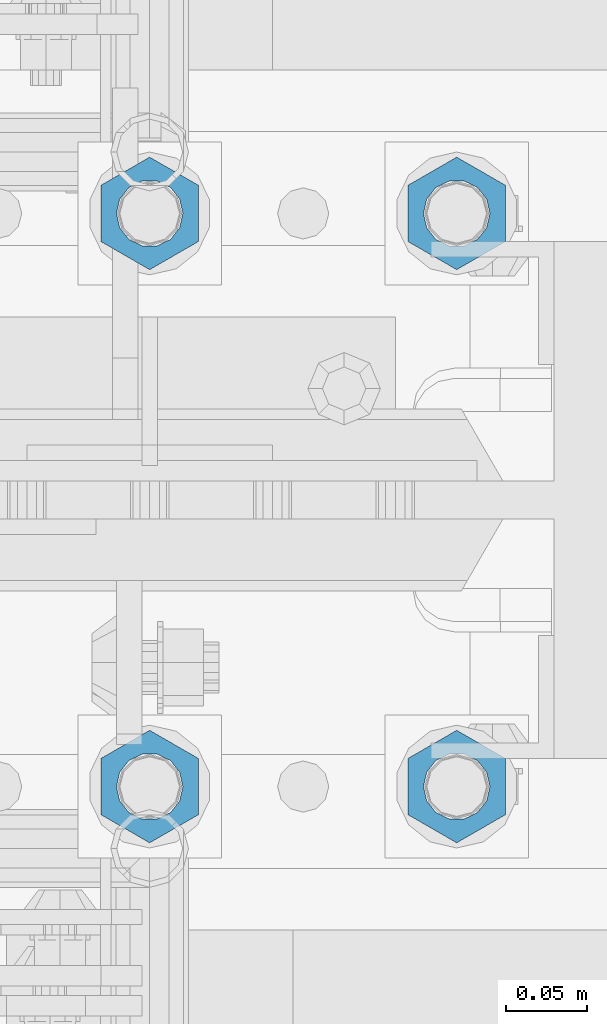
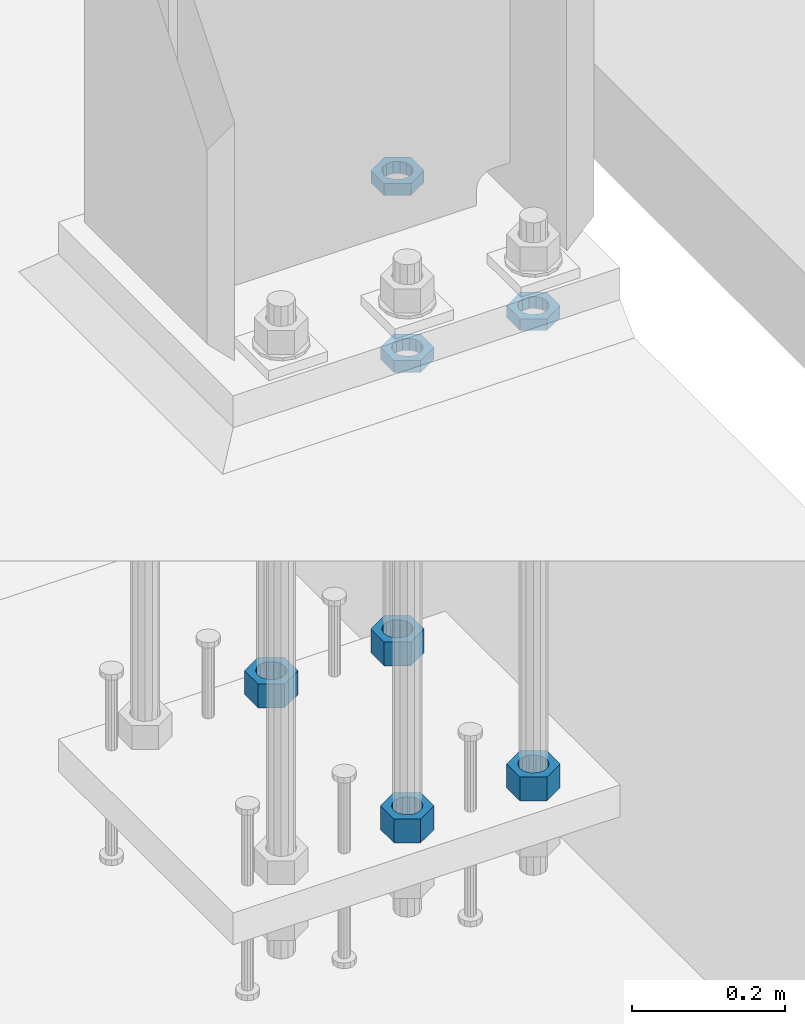
# One storey, part 1394 of 1876: 7 beams, 1 element without a shape of its own.
"""IFC2X3 building model written with IfcOpenShell, lengths in millimetres."""

from ifc_helpers import new_model, si_unit, frame, origin_with_axes, place, context, subcontext, project, spatial, faceted_brep, material, type_object, element, aggregate, save


model = new_model("IFC2X3")

# Units and contexts
model_context = context("Model", 3, precision=1e-05, world=origin_with_axes())
body_context = subcontext(model_context, "Body", "Model", "MODEL_VIEW")
ifc_project = project(units=[si_unit("LENGTHUNIT", "METRE", prefix="MILLI"), si_unit("AREAUNIT", "SQUARE_METRE"), si_unit("VOLUMEUNIT", "CUBIC_METRE"), si_unit("MASSUNIT", "GRAM", prefix="KILO"), si_unit("TIMEUNIT", "SECOND"), si_unit("PLANEANGLEUNIT", "RADIAN"), si_unit("SOLIDANGLEUNIT", "STERADIAN"), si_unit("THERMODYNAMICTEMPERATUREUNIT", "DEGREE_CELSIUS"), si_unit("LUMINOUSINTENSITYUNIT", "LUMEN")], contexts=[model_context])

# Site, building, storey
site_placement = place(None, origin_with_axes())
site = spatial("IfcSite", under=ifc_project, at=site_placement, CompositionType="ELEMENT")
building_placement = place(site_placement, origin_with_axes())
building = spatial("IfcBuilding", under=site, at=building_placement, Name="Undefined", CompositionType="ELEMENT")
storey_placement = place(building_placement, origin_with_axes())
storey = spatial("IfcBuildingStorey", under=building, at=storey_placement, Name="Undefined", CompositionType="ELEMENT", Elevation=0.0)

# Assembly, beams
assembly_placement = place(storey_placement, origin_with_axes())
assembly = element("IfcElementAssembly", 1, at=assembly_placement, inside=storey, Name="TEMPLATE", AssemblyPlace="NOTDEFINED", PredefinedType="RIGID_FRAME")
ifc_material = material(Name="STEEL/A563")
beam_type_1 = type_object("IfcBeamType", Name="1-1/2_DIA. HALF_NUT", PredefinedType="NOTDEFINED")
beam_1_placement = place(assembly_placement, frame((7810.5, -4394.2, 33.3375), z_axis=(-1.0, 0.0, 0.0), x_axis=(0.0, 0.0, -1.0)))
beam_1 = element("IfcBeam", 2, at=beam_1_placement, type_object=beam_type_1, material=ifc_material, Name="NUT", ObjectType="1-1/2_DIA. HALF_NUT", context=body_context, shape_type="Brep", body=[
    faceted_brep([(0.0, -34.9199981689453, 0.0), (0.0, -17.4599990844727, -30.25), (19.0499999999999, -17.4599990844727, -30.25), (19.0499999999999, -34.9199981689453, 0.0), (0.0, 17.4599990844727, -30.25), (19.0499999999999, 17.4599990844727, -30.25), (0.0, 34.9199981689453, 0.0), (19.0499999999999, 34.9199981689453, 0.0), (0.0, 17.4599990844727, 30.25), (19.0499999999999, 17.4599990844727, 30.25), (0.0, -17.4599990844727, 30.25), (19.0499999999999, -17.4599990844727, 30.25), (0.0, 0.0, 20.6399993896484), (0.0, 8.95536011056538, 18.5959968835978), (19.0499999999999, 8.95536011056538, 18.5959968835978), (19.0499999999999, 0.0, 20.6399993896484), (0.0, 16.1370013209489, 12.8688291298158), (19.0499999999999, 16.1370013209489, 12.8688291298158), (0.0, 20.1225115123834, 4.59283194104228), (19.0499999999999, 20.1225115123834, 4.59283194104228), (0.0, 20.1225115123834, -4.59283194104228), (19.0499999999999, 20.1225115123834, -4.59283194104228), (0.0, 16.1370013209489, -12.8688291298167), (19.0499999999999, 16.1370013209489, -12.8688291298167), (0.0, 8.95536011056538, -18.5959968835978), (19.0499999999999, 8.95536011056538, -18.5959968835978), (0.0, 0.0, -20.6399993896484), (19.0499999999999, 0.0, -20.6399993896484), (0.0, -8.95536011056538, -18.5959968835978), (19.0499999999999, -8.95536011056538, -18.5959968835978), (0.0, -16.1370013209489, -12.8688291298158), (19.0499999999999, -16.1370013209489, -12.8688291298158), (0.0, -20.1225115123834, -4.59283194104228), (19.0499999999999, -20.1225115123834, -4.59283194104228), (0.0, -20.1225115123834, 4.59283194104228), (19.0499999999999, -20.1225115123834, 4.59283194104228), (0.0, -16.1370013209489, 12.8688291298167), (19.0499999999999, -16.1370013209489, 12.8688291298167), (0.0, -8.95536011056538, 18.5959968835978), (19.0499999999999, -8.95536011056538, 18.5959968835978)], [[[0, 1, 2, 3]], [[1, 4, 5, 2]], [[4, 6, 7, 5]], [[6, 8, 9, 7]], [[8, 10, 11, 9]], [[10, 0, 3, 11]], [[12, 13, 14, 15]], [[13, 16, 17, 14]], [[16, 18, 19, 17]], [[18, 20, 21, 19]], [[20, 22, 23, 21]], [[22, 24, 25, 23]], [[24, 26, 27, 25]], [[26, 28, 29, 27]], [[28, 30, 31, 29]], [[30, 32, 33, 31]], [[32, 34, 35, 33]], [[34, 36, 37, 35]], [[36, 38, 39, 37]], [[38, 12, 15, 39]], [[5, 7, 9, 11, 3, 2], [17, 19, 21, 23, 25, 27, 29, 31, 33, 35, 37, 39, 15, 14]], [[10, 8, 6, 4, 1, 0], [38, 36, 34, 32, 30, 28, 26, 24, 22, 20, 18, 16, 13, 12]]]),
])
beam_2_placement = place(assembly_placement, frame((7620.0, -4749.8, 33.3375), z_axis=(1.0, 0.0, 0.0), x_axis=(0.0, 0.0, -1.0)))
beam_2 = element("IfcBeam", 3, at=beam_2_placement, type_object=beam_type_1, material=ifc_material, Name="NUT", ObjectType="1-1/2_DIA. HALF_NUT", context=body_context, shape_type="Brep", body=[
    faceted_brep([(0.0, -34.9199981689453, 0.0), (0.0, -17.4599990844727, -30.25), (19.0499999999999, -17.4599990844727, -30.25), (19.0499999999999, -34.9199981689453, 0.0), (0.0, 17.4599990844727, -30.25), (19.0499999999999, 17.4599990844727, -30.25), (0.0, 34.9199981689453, 0.0), (19.0499999999999, 34.9199981689453, 0.0), (0.0, 17.4599990844727, 30.25), (19.0499999999999, 17.4599990844727, 30.25), (0.0, -17.4599990844727, 30.25), (19.0499999999999, -17.4599990844727, 30.25), (0.0, 0.0, 20.6399993896484), (0.0, 8.95536011056538, 18.5959968835978), (19.0499999999999, 8.95536011056538, 18.5959968835978), (19.0499999999999, 0.0, 20.6399993896484), (0.0, 16.1370013209489, 12.8688291298158), (19.0499999999999, 16.1370013209489, 12.8688291298158), (0.0, 20.1225115123834, 4.59283194104228), (19.0499999999999, 20.1225115123834, 4.59283194104228), (0.0, 20.1225115123834, -4.59283194104228), (19.0499999999999, 20.1225115123834, -4.59283194104228), (0.0, 16.1370013209489, -12.8688291298167), (19.0499999999999, 16.1370013209489, -12.8688291298167), (0.0, 8.95536011056538, -18.5959968835978), (19.0499999999999, 8.95536011056538, -18.5959968835978), (0.0, 0.0, -20.6399993896484), (19.0499999999999, 0.0, -20.6399993896484), (0.0, -8.95536011056538, -18.5959968835978), (19.0499999999999, -8.95536011056538, -18.5959968835978), (0.0, -16.1370013209489, -12.8688291298158), (19.0499999999999, -16.1370013209489, -12.8688291298158), (0.0, -20.1225115123834, -4.59283194104228), (19.0499999999999, -20.1225115123834, -4.59283194104228), (0.0, -20.1225115123834, 4.59283194104228), (19.0499999999999, -20.1225115123834, 4.59283194104228), (0.0, -16.1370013209489, 12.8688291298167), (19.0499999999999, -16.1370013209489, 12.8688291298167), (0.0, -8.95536011056538, 18.5959968835978), (19.0499999999999, -8.95536011056538, 18.5959968835978)], [[[0, 1, 2, 3]], [[1, 4, 5, 2]], [[4, 6, 7, 5]], [[6, 8, 9, 7]], [[8, 10, 11, 9]], [[10, 0, 3, 11]], [[12, 13, 14, 15]], [[13, 16, 17, 14]], [[16, 18, 19, 17]], [[18, 20, 21, 19]], [[20, 22, 23, 21]], [[22, 24, 25, 23]], [[24, 26, 27, 25]], [[26, 28, 29, 27]], [[28, 30, 31, 29]], [[30, 32, 33, 31]], [[32, 34, 35, 33]], [[34, 36, 37, 35]], [[36, 38, 39, 37]], [[38, 12, 15, 39]], [[5, 7, 9, 11, 3, 2], [17, 19, 21, 23, 25, 27, 29, 31, 33, 35, 37, 39, 15, 14]], [[10, 8, 6, 4, 1, 0], [38, 36, 34, 32, 30, 28, 26, 24, 22, 20, 18, 16, 13, 12]]]),
])
beam_3_placement = place(assembly_placement, frame((7810.5, -4749.8, 33.3375), z_axis=(1.0, 0.0, 0.0), x_axis=(0.0, 0.0, -1.0)))
beam_3 = element("IfcBeam", 4, at=beam_3_placement, type_object=beam_type_1, material=ifc_material, Name="NUT", ObjectType="1-1/2_DIA. HALF_NUT", context=body_context, shape_type="Brep", body=[
    faceted_brep([(0.0, -34.9199981689453, 0.0), (0.0, -17.4599990844727, -30.25), (19.0499999999999, -17.4599990844727, -30.25), (19.0499999999999, -34.9199981689453, 0.0), (0.0, 17.4599990844727, -30.25), (19.0499999999999, 17.4599990844727, -30.25), (0.0, 34.9199981689453, 0.0), (19.0499999999999, 34.9199981689453, 0.0), (0.0, 17.4599990844727, 30.25), (19.0499999999999, 17.4599990844727, 30.25), (0.0, -17.4599990844727, 30.25), (19.0499999999999, -17.4599990844727, 30.25), (0.0, 0.0, 20.6399993896484), (0.0, 8.95536011056538, 18.5959968835978), (19.0499999999999, 8.95536011056538, 18.5959968835978), (19.0499999999999, 0.0, 20.6399993896484), (0.0, 16.1370013209489, 12.8688291298158), (19.0499999999999, 16.1370013209489, 12.8688291298158), (0.0, 20.1225115123834, 4.59283194104228), (19.0499999999999, 20.1225115123834, 4.59283194104228), (0.0, 20.1225115123834, -4.59283194104228), (19.0499999999999, 20.1225115123834, -4.59283194104228), (0.0, 16.1370013209489, -12.8688291298167), (19.0499999999999, 16.1370013209489, -12.8688291298167), (0.0, 8.95536011056538, -18.5959968835978), (19.0499999999999, 8.95536011056538, -18.5959968835978), (0.0, 0.0, -20.6399993896484), (19.0499999999999, 0.0, -20.6399993896484), (0.0, -8.95536011056538, -18.5959968835978), (19.0499999999999, -8.95536011056538, -18.5959968835978), (0.0, -16.1370013209489, -12.8688291298158), (19.0499999999999, -16.1370013209489, -12.8688291298158), (0.0, -20.1225115123834, -4.59283194104228), (19.0499999999999, -20.1225115123834, -4.59283194104228), (0.0, -20.1225115123834, 4.59283194104228), (19.0499999999999, -20.1225115123834, 4.59283194104228), (0.0, -16.1370013209489, 12.8688291298167), (19.0499999999999, -16.1370013209489, 12.8688291298167), (0.0, -8.95536011056538, 18.5959968835978), (19.0499999999999, -8.95536011056538, 18.5959968835978)], [[[0, 1, 2, 3]], [[1, 4, 5, 2]], [[4, 6, 7, 5]], [[6, 8, 9, 7]], [[8, 10, 11, 9]], [[10, 0, 3, 11]], [[12, 13, 14, 15]], [[13, 16, 17, 14]], [[16, 18, 19, 17]], [[18, 20, 21, 19]], [[20, 22, 23, 21]], [[22, 24, 25, 23]], [[24, 26, 27, 25]], [[26, 28, 29, 27]], [[28, 30, 31, 29]], [[30, 32, 33, 31]], [[32, 34, 35, 33]], [[34, 36, 37, 35]], [[36, 38, 39, 37]], [[38, 12, 15, 39]], [[5, 7, 9, 11, 3, 2], [17, 19, 21, 23, 25, 27, 29, 31, 33, 35, 37, 39, 15, 14]], [[10, 8, 6, 4, 1, 0], [38, 36, 34, 32, 30, 28, 26, 24, 22, 20, 18, 16, 13, 12]]]),
])
beam_type_2 = type_object("IfcBeamType", Name="1-1/2_HEAVY_HEX_NUT", PredefinedType="NOTDEFINED")
beam_4_placement = place(assembly_placement, frame((7810.5, -4749.8, -698.5), z_axis=(1.0, 0.0, 0.0), x_axis=(0.0, 0.0, -1.0)))
beam_4 = element("IfcBeam", 5, at=beam_4_placement, type_object=beam_type_2, material=ifc_material, Name="NUT", ObjectType="1-1/2_HEAVY_HEX_NUT", context=body_context, shape_type="Brep", body=[
    faceted_brep([(0.0, -34.9199981689453, 0.0), (0.0, -17.4599990844727, -30.25), (38.1, -17.4599990844727, -30.25), (38.1, -34.9199981689453, 0.0), (0.0, 17.4599990844727, -30.25), (38.1, 17.4599990844727, -30.25), (0.0, 34.9199981689453, 0.0), (38.1, 34.9199981689453, 0.0), (0.0, 17.4599990844727, 30.25), (38.1, 17.4599990844727, 30.25), (0.0, -17.4599990844727, 30.25), (38.1, -17.4599990844727, 30.25), (0.0, 0.0, 20.6399993896484), (0.0, 8.95536011056538, 18.5959968835978), (38.1, 8.95536011056447, 18.595996883598), (38.1, 0.0, 20.6399993896484), (0.0, 16.1370013209489, 12.8688291298158), (38.1, 16.137001320948, 12.8688291298162), (0.0, 20.1225115123834, 4.59283194104228), (38.1, 20.1225115123843, 4.59283194104222), (0.0, 20.1225115123834, -4.59283194104228), (38.1, 20.1225115123843, -4.59283194104239), (0.0, 16.1370013209489, -12.8688291298167), (38.1, 16.137001320948, -12.8688291298163), (0.0, 8.95536011056538, -18.5959968835978), (38.1, 8.95536011056447, -18.5959968835982), (0.0, 0.0, -20.6399993896484), (38.1, 0.0, -20.6399993896484), (0.0, -8.95536011056538, -18.5959968835978), (38.1, -8.95536011056447, -18.595996883598), (0.0, -16.1370013209489, -12.8688291298158), (38.1, -16.137001320948, -12.8688291298162), (0.0, -20.1225115123834, -4.59283194104228), (38.1, -20.1225115123843, -4.59283194104222), (0.0, -20.1225115123834, 4.59283194104228), (38.1, -20.1225115123843, 4.59283194104239), (0.0, -16.1370013209489, 12.8688291298167), (38.1, -16.137001320948, 12.8688291298163), (0.0, -8.95536011056538, 18.5959968835978), (38.1, -8.95536011056447, 18.5959968835982)], [[[0, 1, 2, 3]], [[1, 4, 5, 2]], [[4, 6, 7, 5]], [[6, 8, 9, 7]], [[8, 10, 11, 9]], [[10, 0, 3, 11]], [[12, 13, 14, 15]], [[13, 16, 17, 14]], [[16, 18, 19, 17]], [[18, 20, 21, 19]], [[20, 22, 23, 21]], [[22, 24, 25, 23]], [[24, 26, 27, 25]], [[26, 28, 29, 27]], [[28, 30, 31, 29]], [[30, 32, 33, 31]], [[32, 34, 35, 33]], [[34, 36, 37, 35]], [[36, 38, 39, 37]], [[38, 12, 15, 39]], [[5, 7, 9, 11, 3, 2], [17, 19, 21, 23, 25, 27, 29, 31, 33, 35, 37, 39, 15, 14]], [[10, 8, 6, 4, 1, 0], [38, 36, 34, 32, 30, 28, 26, 24, 22, 20, 18, 16, 13, 12]]]),
])
beam_5_placement = place(assembly_placement, frame((7810.5, -4394.2, -698.5), z_axis=(-1.0, 0.0, 0.0), x_axis=(0.0, 0.0, -1.0)))
beam_5 = element("IfcBeam", 6, at=beam_5_placement, type_object=beam_type_2, material=ifc_material, Name="NUT", ObjectType="1-1/2_HEAVY_HEX_NUT", context=body_context, shape_type="Brep", body=[
    faceted_brep([(0.0, -34.9199981689453, 0.0), (0.0, -17.4599990844727, -30.25), (38.1, -17.4599990844727, -30.25), (38.1, -34.9199981689453, 0.0), (0.0, 17.4599990844727, -30.25), (38.1, 17.4599990844727, -30.25), (0.0, 34.9199981689453, 0.0), (38.1, 34.9199981689453, 0.0), (0.0, 17.4599990844727, 30.25), (38.1, 17.4599990844727, 30.25), (0.0, -17.4599990844727, 30.25), (38.1, -17.4599990844727, 30.25), (0.0, 0.0, 20.6399993896484), (0.0, 8.95536011056538, 18.5959968835978), (38.1, 8.95536011056447, 18.595996883598), (38.1, 0.0, 20.6399993896484), (0.0, 16.1370013209489, 12.8688291298158), (38.1, 16.137001320948, 12.8688291298162), (0.0, 20.1225115123834, 4.59283194104228), (38.1, 20.1225115123843, 4.59283194104222), (0.0, 20.1225115123834, -4.59283194104228), (38.1, 20.1225115123843, -4.59283194104239), (0.0, 16.1370013209489, -12.8688291298167), (38.1, 16.137001320948, -12.8688291298163), (0.0, 8.95536011056538, -18.5959968835978), (38.1, 8.95536011056447, -18.5959968835982), (0.0, 0.0, -20.6399993896484), (38.1, 0.0, -20.6399993896484), (0.0, -8.95536011056538, -18.5959968835978), (38.1, -8.95536011056447, -18.595996883598), (0.0, -16.1370013209489, -12.8688291298158), (38.1, -16.137001320948, -12.8688291298162), (0.0, -20.1225115123834, -4.59283194104228), (38.1, -20.1225115123843, -4.59283194104222), (0.0, -20.1225115123834, 4.59283194104228), (38.1, -20.1225115123843, 4.59283194104239), (0.0, -16.1370013209489, 12.8688291298167), (38.1, -16.137001320948, 12.8688291298163), (0.0, -8.95536011056538, 18.5959968835978), (38.1, -8.95536011056447, 18.5959968835982)], [[[0, 1, 2, 3]], [[1, 4, 5, 2]], [[4, 6, 7, 5]], [[6, 8, 9, 7]], [[8, 10, 11, 9]], [[10, 0, 3, 11]], [[12, 13, 14, 15]], [[13, 16, 17, 14]], [[16, 18, 19, 17]], [[18, 20, 21, 19]], [[20, 22, 23, 21]], [[22, 24, 25, 23]], [[24, 26, 27, 25]], [[26, 28, 29, 27]], [[28, 30, 31, 29]], [[30, 32, 33, 31]], [[32, 34, 35, 33]], [[34, 36, 37, 35]], [[36, 38, 39, 37]], [[38, 12, 15, 39]], [[5, 7, 9, 11, 3, 2], [17, 19, 21, 23, 25, 27, 29, 31, 33, 35, 37, 39, 15, 14]], [[10, 8, 6, 4, 1, 0], [38, 36, 34, 32, 30, 28, 26, 24, 22, 20, 18, 16, 13, 12]]]),
])
beam_6_placement = place(assembly_placement, frame((7620.0, -4749.8, -698.5), z_axis=(1.0, 0.0, 0.0), x_axis=(0.0, 0.0, -1.0)))
beam_6 = element("IfcBeam", 7, at=beam_6_placement, type_object=beam_type_2, material=ifc_material, Name="NUT", ObjectType="1-1/2_HEAVY_HEX_NUT", context=body_context, shape_type="Brep", body=[
    faceted_brep([(0.0, -34.9199981689453, 0.0), (0.0, -17.4599990844727, -30.25), (38.1, -17.4599990844727, -30.25), (38.1, -34.9199981689453, 0.0), (0.0, 17.4599990844727, -30.25), (38.1, 17.4599990844727, -30.25), (0.0, 34.9199981689453, 0.0), (38.1, 34.9199981689453, 0.0), (0.0, 17.4599990844727, 30.25), (38.1, 17.4599990844727, 30.25), (0.0, -17.4599990844727, 30.25), (38.1, -17.4599990844727, 30.25), (0.0, 0.0, 20.6399993896484), (0.0, 8.95536011056538, 18.5959968835978), (38.1, 8.95536011056447, 18.595996883598), (38.1, 0.0, 20.6399993896484), (0.0, 16.1370013209489, 12.8688291298158), (38.1, 16.137001320948, 12.8688291298162), (0.0, 20.1225115123834, 4.59283194104228), (38.1, 20.1225115123843, 4.59283194104222), (0.0, 20.1225115123834, -4.59283194104228), (38.1, 20.1225115123843, -4.59283194104239), (0.0, 16.1370013209489, -12.8688291298167), (38.1, 16.137001320948, -12.8688291298163), (0.0, 8.95536011056538, -18.5959968835978), (38.1, 8.95536011056447, -18.5959968835982), (0.0, 0.0, -20.6399993896484), (38.1, 0.0, -20.6399993896484), (0.0, -8.95536011056538, -18.5959968835978), (38.1, -8.95536011056447, -18.595996883598), (0.0, -16.1370013209489, -12.8688291298158), (38.1, -16.137001320948, -12.8688291298162), (0.0, -20.1225115123834, -4.59283194104228), (38.1, -20.1225115123843, -4.59283194104222), (0.0, -20.1225115123834, 4.59283194104228), (38.1, -20.1225115123843, 4.59283194104239), (0.0, -16.1370013209489, 12.8688291298167), (38.1, -16.137001320948, 12.8688291298163), (0.0, -8.95536011056538, 18.5959968835978), (38.1, -8.95536011056447, 18.5959968835982)], [[[0, 1, 2, 3]], [[1, 4, 5, 2]], [[4, 6, 7, 5]], [[6, 8, 9, 7]], [[8, 10, 11, 9]], [[10, 0, 3, 11]], [[12, 13, 14, 15]], [[13, 16, 17, 14]], [[16, 18, 19, 17]], [[18, 20, 21, 19]], [[20, 22, 23, 21]], [[22, 24, 25, 23]], [[24, 26, 27, 25]], [[26, 28, 29, 27]], [[28, 30, 31, 29]], [[30, 32, 33, 31]], [[32, 34, 35, 33]], [[34, 36, 37, 35]], [[36, 38, 39, 37]], [[38, 12, 15, 39]], [[5, 7, 9, 11, 3, 2], [17, 19, 21, 23, 25, 27, 29, 31, 33, 35, 37, 39, 15, 14]], [[10, 8, 6, 4, 1, 0], [38, 36, 34, 32, 30, 28, 26, 24, 22, 20, 18, 16, 13, 12]]]),
])
beam_7_placement = place(assembly_placement, frame((7620.0, -4394.2, -698.5), z_axis=(-1.0, 0.0, 0.0), x_axis=(0.0, 0.0, -1.0)))
beam_7 = element("IfcBeam", 8, at=beam_7_placement, type_object=beam_type_2, material=ifc_material, Name="NUT", ObjectType="1-1/2_HEAVY_HEX_NUT", context=body_context, shape_type="Brep", body=[
    faceted_brep([(0.0, -34.9199981689453, 0.0), (0.0, -17.4599990844727, -30.25), (38.1, -17.4599990844727, -30.25), (38.1, -34.9199981689453, 0.0), (0.0, 17.4599990844727, -30.25), (38.1, 17.4599990844727, -30.25), (0.0, 34.9199981689453, 0.0), (38.1, 34.9199981689453, 0.0), (0.0, 17.4599990844727, 30.25), (38.1, 17.4599990844727, 30.25), (0.0, -17.4599990844727, 30.25), (38.1, -17.4599990844727, 30.25), (0.0, 0.0, 20.6399993896484), (0.0, 8.95536011056538, 18.5959968835978), (38.1, 8.95536011056447, 18.595996883598), (38.1, 0.0, 20.6399993896484), (0.0, 16.1370013209489, 12.8688291298158), (38.1, 16.137001320948, 12.8688291298162), (0.0, 20.1225115123834, 4.59283194104228), (38.1, 20.1225115123843, 4.59283194104222), (0.0, 20.1225115123834, -4.59283194104228), (38.1, 20.1225115123843, -4.59283194104239), (0.0, 16.1370013209489, -12.8688291298167), (38.1, 16.137001320948, -12.8688291298163), (0.0, 8.95536011056538, -18.5959968835978), (38.1, 8.95536011056447, -18.5959968835982), (0.0, 0.0, -20.6399993896484), (38.1, 0.0, -20.6399993896484), (0.0, -8.95536011056538, -18.5959968835978), (38.1, -8.95536011056447, -18.595996883598), (0.0, -16.1370013209489, -12.8688291298158), (38.1, -16.137001320948, -12.8688291298162), (0.0, -20.1225115123834, -4.59283194104228), (38.1, -20.1225115123843, -4.59283194104222), (0.0, -20.1225115123834, 4.59283194104228), (38.1, -20.1225115123843, 4.59283194104239), (0.0, -16.1370013209489, 12.8688291298167), (38.1, -16.137001320948, 12.8688291298163), (0.0, -8.95536011056538, 18.5959968835978), (38.1, -8.95536011056447, 18.5959968835982)], [[[0, 1, 2, 3]], [[1, 4, 5, 2]], [[4, 6, 7, 5]], [[6, 8, 9, 7]], [[8, 10, 11, 9]], [[10, 0, 3, 11]], [[12, 13, 14, 15]], [[13, 16, 17, 14]], [[16, 18, 19, 17]], [[18, 20, 21, 19]], [[20, 22, 23, 21]], [[22, 24, 25, 23]], [[24, 26, 27, 25]], [[26, 28, 29, 27]], [[28, 30, 31, 29]], [[30, 32, 33, 31]], [[32, 34, 35, 33]], [[34, 36, 37, 35]], [[36, 38, 39, 37]], [[38, 12, 15, 39]], [[5, 7, 9, 11, 3, 2], [17, 19, 21, 23, 25, 27, 29, 31, 33, 35, 37, 39, 15, 14]], [[10, 8, 6, 4, 1, 0], [38, 36, 34, 32, 30, 28, 26, 24, 22, 20, 18, 16, 13, 12]]]),
])
aggregate(assembly, [beam_1, beam_2, beam_3, beam_4, beam_5, beam_6, beam_7])

save(model, "model.ifc")
